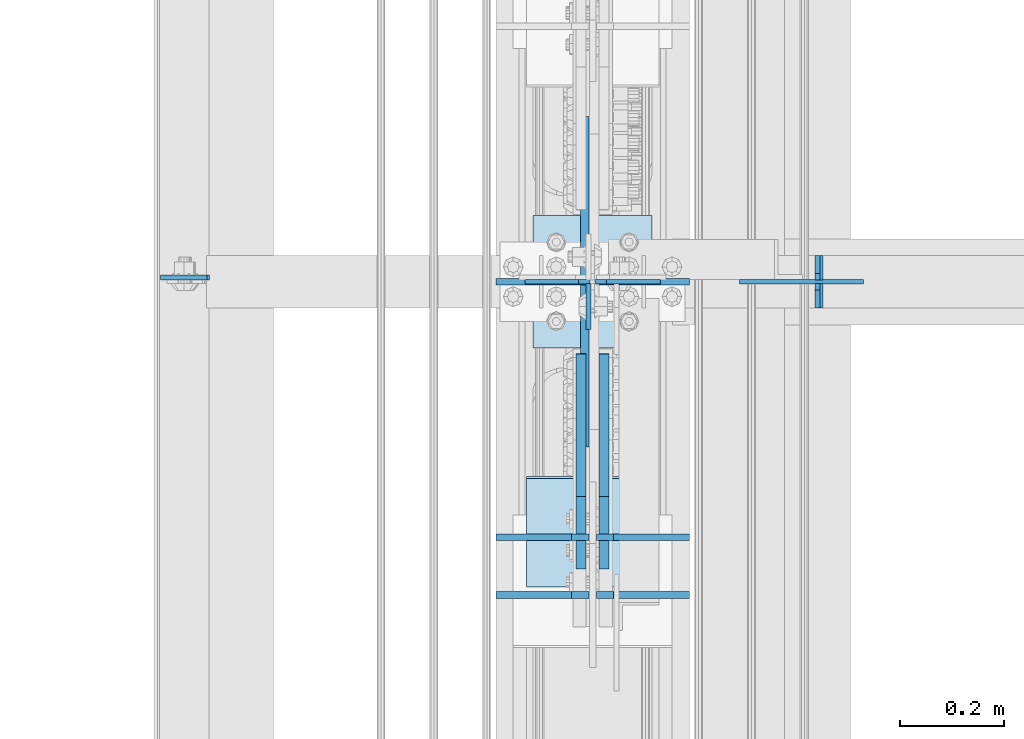
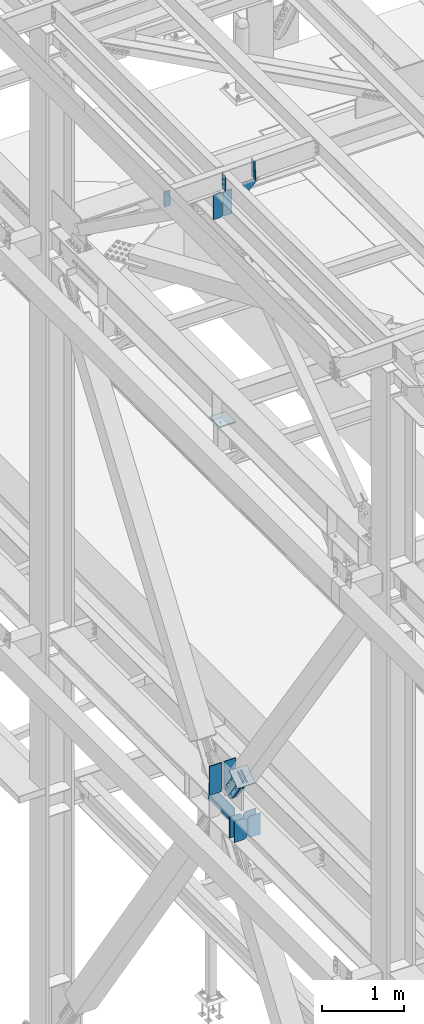
# One storey, part 3347 of 3843: 18 plates, 8 elements without a shape of their own.
"""IFC2X3 building model written with IfcOpenShell, lengths in millimetres."""

from ifc_helpers import new_model, si_unit, frame, origin_with_axes, place, context, subcontext, project, spatial, faceted_brep, material, type_object, element, aggregate, save


model = new_model("IFC2X3")

# Units and contexts
model_context = context("Model", 3, precision=1e-05, world=origin_with_axes())
body_context = subcontext(model_context, "Body", "Model", "MODEL_VIEW")
ifc_project = project(units=[si_unit("LENGTHUNIT", "METRE", prefix="MILLI"), si_unit("AREAUNIT", "SQUARE_METRE"), si_unit("VOLUMEUNIT", "CUBIC_METRE"), si_unit("MASSUNIT", "GRAM", prefix="KILO"), si_unit("TIMEUNIT", "SECOND"), si_unit("PLANEANGLEUNIT", "RADIAN"), si_unit("SOLIDANGLEUNIT", "STERADIAN"), si_unit("THERMODYNAMICTEMPERATUREUNIT", "DEGREE_CELSIUS"), si_unit("LUMINOUSINTENSITYUNIT", "LUMEN")], contexts=[model_context])

# Site, building, storey
site_placement = place(None, origin_with_axes())
site = spatial("IfcSite", under=ifc_project, at=site_placement, CompositionType="ELEMENT")
building_placement = place(site_placement, origin_with_axes())
building = spatial("IfcBuilding", under=site, at=building_placement, Name="Undefined", CompositionType="ELEMENT")
storey_placement = place(building_placement, origin_with_axes())
storey = spatial("IfcBuildingStorey", under=building, at=storey_placement, Name="Undefined", CompositionType="ELEMENT", Elevation=0.0)

# Assembly, plate
assembly_1_placement = place(storey_placement, origin_with_axes())
assembly_1 = element("IfcElementAssembly", 1, at=assembly_1_placement, inside=storey, Name="BEAM", AssemblyPlace="NOTDEFINED", PredefinedType="RIGID_FRAME")
ifc_material_1 = material(Name="STEEL/A572-50")
plate_type_1 = type_object("IfcPlateType", PredefinedType="NOTDEFINED")
plate_1_placement = place(assembly_1_placement, frame((36568.0624999624, 71447.0249999999, 45691.4946293707), z_axis=(0.0, -1.0, 0.0), x_axis=(0.0, 0.0, -1.0)))
plate_1 = element("IfcPlate", 2, at=plate_1_placement, type_object=plate_type_1, material=ifc_material_1, Name="PLATE", context=body_context, shape_type="Brep", body=[
    faceted_brep([(0.0, -4.76249999999709, 0.0), (0.0, -4.76249999999709, 88.9000015258789), (0.0, 4.76249999999709, 88.9000015258789), (0.0, 4.76249999999709, 0.0), (228.600006102781, -4.7625000004191, 88.9000015257589), (228.600006102781, 4.76249999954598, 88.9000015257443), (228.600006103079, -4.7625000004482, 7.27595761418343e-12), (228.600006103079, 4.76249999954598, -7.27595761418343e-12)], [[[0, 1, 2, 3]], [[1, 4, 5, 2]], [[4, 6, 7, 5]], [[6, 0, 3, 7]], [[5, 7, 3, 2]], [[6, 4, 1, 0]]]),
])

assembly_2_placement = place(storey_placement, origin_with_axes())
assembly_2 = element("IfcElementAssembly", 3, at=assembly_2_placement, inside=storey, Name="BEAM", AssemblyPlace="NOTDEFINED", PredefinedType="RIGID_FRAME")
plate_2_placement = place(assembly_2_placement, frame((35746.5416190487, 71458.1374999999, 45673.93739218), z_axis=(0.999776270257024, 0.0, 0.0211520550054619), x_axis=(0.0211520550054438, 0.0, -0.999776270257025)))
plate_2 = element("IfcPlate", 4, at=plate_2_placement, type_object=plate_type_1, material=ifc_material_1, Name="PLATE", context=body_context, shape_type="Brep", body=[
    faceted_brep([(0.0, -4.76249999999709, 0.0), (0.0, -4.76249999999709, 88.9000015258789), (0.0, 4.76249999999709, 88.9000015258789), (0.0, 4.76249999999709, 0.0), (228.600006102781, -4.7625000004191, 88.9000015257589), (228.600006102781, 4.76249999954598, 88.9000015257443), (228.600006103079, -4.7625000004482, 7.27595761418343e-12), (228.600006103079, 4.76249999954598, -7.27595761418343e-12)], [[[0, 1, 2, 3]], [[1, 4, 5, 2]], [[4, 6, 7, 5]], [[6, 0, 3, 7]], [[5, 7, 3, 2]], [[6, 4, 1, 0]]]),
])
aggregate(assembly_2, [plate_2])

# Plate
plate_type_2 = type_object("IfcPlateType", PredefinedType="NOTDEFINED")
plate_3_placement = place(assembly_1_placement, frame((37013.8586767906, 71399.3999999999, 45441.9293994939), z_axis=(-0.0211520980073474, 0.0, 0.999776269347241), x_axis=(0.0, 1.0, 0.0)))
plate_3 = element("IfcPlate", 5, at=plate_3_placement, type_object=plate_type_2, material=ifc_material_1, Name="STIFFENER", context=body_context, shape_type="Brep", body=[
    faceted_brep([(0.0, -4.76249999999709, 0.0), (0.0, -4.7624999997206, 285.749999997672), (0.0, 4.7625000002663, 285.749999997664), (0.0, 4.76249999999709, 0.0), (34.9250001907349, -4.7624999997206, 285.749999997672), (34.9250001907349, 4.7625000002663, 285.749999997664), (47.625, -4.76249999972788, 273.050000188428), (47.625, 4.76250000025902, 273.050000188421), (47.625, -4.76249999998981, 12.6999998092579), (47.625, 4.76249999999709, 12.6999998092506), (34.9250001907349, -4.76249999999709, 1.45519152283669e-11), (34.9250001907349, 4.76249999998254, 0.0)], [[[0, 1, 2, 3]], [[1, 4, 5, 2]], [[4, 6, 7, 5]], [[6, 8, 9, 7]], [[8, 10, 11, 9]], [[10, 0, 3, 11]], [[5, 7, 9, 11, 3, 2]], [[10, 8, 6, 4, 1, 0]]]),
])

plate_4_placement = place(assembly_1_placement, frame((37013.8586767906, 71453.3749999999, 45441.9293994939), z_axis=(-0.0211520980073474, 0.0, 0.999776269347241), x_axis=(0.0, 1.0, 0.0)))
plate_4 = element("IfcPlate", 6, at=plate_4_placement, type_object=plate_type_2, material=ifc_material_1, Name="STIFFENER", context=body_context, shape_type="Brep", body=[
    faceted_brep([(0.0, -4.76250000000073, 12.6999998092651), (0.0, -4.76250000000073, 273.050000188858), (0.0, 4.76250000000073, 273.050000188858), (0.0, 4.76250000000073, 12.6999998092651), (12.6999998092651, -4.76250000000073, 285.749999998123), (12.6999998092651, 4.76250000000073, 285.749999998123), (47.625, -4.76250000000073, 285.749999998123), (47.625, 4.76250000000073, 285.749999998123), (47.625, -4.76250000000073, 0.0), (47.625, 4.76250000000073, 0.0), (12.6999998092651, -4.76250000000073, 0.0), (12.6999998092651, 4.76250000000073, 0.0)], [[[0, 1, 2, 3]], [[1, 4, 5, 2]], [[4, 6, 7, 5]], [[6, 8, 9, 7]], [[8, 10, 11, 9]], [[10, 0, 3, 11]], [[5, 7, 9, 11, 3, 2]], [[10, 8, 6, 4, 1, 0]]]),
])

# Assembly, plates
assembly_3_placement = place(storey_placement, origin_with_axes())
assembly_3 = element("IfcElementAssembly", 7, at=assembly_3_placement, inside=storey, Name="BEAM", AssemblyPlace="NOTDEFINED", PredefinedType="RIGID_FRAME")
plate_type_3 = type_object("IfcPlateType", PredefinedType="NOTDEFINED")
plate_5_placement = place(assembly_3_placement, frame((36568.85625, 70848.9295924979, 36093.4), z_axis=(-1.0, 0.0, 0.0), x_axis=(0.0, 0.0, 1.0)))
plate_5 = element("IfcPlate", 8, at=plate_5_placement, type_object=plate_type_3, material=ifc_material_1, Name="CB_BEAM", context=body_context, shape_type="Brep", body=[
    faceted_brep([(0.0, -6.34999999999854, 33.3375015258789), (0.0, -6.34999999999854, 178.59375), (0.0, 6.34999999999854, 178.59375), (0.0, 6.34999999999854, 33.3375015258789), (317.499999999985, -6.34999999999854, 178.59375), (317.499999999985, 6.34999999999854, 178.59375), (317.499999999985, -6.34999999999854, 33.3375015258789), (317.499999999985, 6.34999999999854, 33.3375015258789), (284.162498474107, -6.34999999999854, 0.0), (284.162498474107, 6.34999999999854, 0.0), (33.3375015258789, -6.34999999999854, 0.0), (33.3375015258789, 6.34999999999854, 0.0)], [[[0, 1, 2, 3]], [[1, 4, 5, 2]], [[4, 6, 7, 5]], [[6, 8, 9, 7]], [[8, 10, 11, 9]], [[10, 0, 3, 11]], [[5, 7, 9, 11, 3, 2]], [[10, 8, 6, 4, 1, 0]]]),
])
plate_6_placement = place(assembly_3_placement, frame((36583.14375, 70848.9295924979, 36093.4), z_axis=(1.0, 0.0, 0.0), x_axis=(0.0, 0.0, 1.0)))
plate_6 = element("IfcPlate", 9, at=plate_6_placement, type_object=plate_type_3, material=ifc_material_1, Name="CB_BEAM", context=body_context, shape_type="Brep", body=[
    faceted_brep([(0.0, -6.34999999999854, 33.3375015258789), (0.0, -6.34999999999854, 178.59375), (0.0, 6.34999999999854, 178.59375), (0.0, 6.34999999999854, 33.3375015258789), (317.499999999985, -6.34999999999854, 178.59375), (317.499999999985, 6.34999999999854, 178.59375), (317.499999999985, -6.34999999999854, 33.3375015258789), (317.499999999985, 6.34999999999854, 33.3375015258789), (284.162498474107, -6.34999999999854, 0.0), (284.162498474107, 6.34999999999854, 0.0), (33.3375015258789, -6.34999999999854, 0.0), (33.3375015258789, 6.34999999999854, 0.0)], [[[0, 1, 2, 3]], [[1, 4, 5, 2]], [[4, 6, 7, 5]], [[6, 8, 9, 7]], [[8, 10, 11, 9]], [[10, 0, 3, 11]], [[5, 7, 9, 11, 3, 2]], [[10, 8, 6, 4, 1, 0]]]),
])
plate_7_placement = place(assembly_3_placement, frame((36568.85625, 70959.9507437756, 36093.4), z_axis=(-1.0, 0.0, 0.0), x_axis=(0.0, 0.0, 1.0)))
plate_7 = element("IfcPlate", 10, at=plate_7_placement, type_object=plate_type_3, material=ifc_material_1, Name="CB_BEAM", context=body_context, shape_type="Brep", body=[
    faceted_brep([(0.0, -6.34999999999854, 33.3375015258789), (0.0, -6.34999999999854, 178.59375), (0.0, 6.34999999999854, 178.59375), (0.0, 6.34999999999854, 33.3375015258789), (317.499999999985, -6.34999999999854, 178.59375), (317.499999999985, 6.34999999999854, 178.59375), (317.499999999985, -6.34999999999854, 33.3375015258789), (317.499999999985, 6.34999999999854, 33.3375015258789), (284.162498474107, -6.34999999999854, 0.0), (284.162498474107, 6.34999999999854, 0.0), (33.3375015258789, -6.34999999999854, 0.0), (33.3375015258789, 6.34999999999854, 0.0)], [[[0, 1, 2, 3]], [[1, 4, 5, 2]], [[4, 6, 7, 5]], [[6, 8, 9, 7]], [[8, 10, 11, 9]], [[10, 0, 3, 11]], [[5, 7, 9, 11, 3, 2]], [[10, 8, 6, 4, 1, 0]]]),
])
plate_8_placement = place(assembly_3_placement, frame((36583.14375, 70959.9507437756, 36093.4), z_axis=(1.0, 0.0, 0.0), x_axis=(0.0, 0.0, 1.0)))
plate_8 = element("IfcPlate", 11, at=plate_8_placement, type_object=plate_type_3, material=ifc_material_1, Name="CB_BEAM", context=body_context, shape_type="Brep", body=[
    faceted_brep([(0.0, -6.34999999999854, 33.3375015258789), (0.0, -6.34999999999854, 178.59375), (0.0, 6.34999999999854, 178.59375), (0.0, 6.34999999999854, 33.3375015258789), (317.499999999985, -6.34999999999854, 178.59375), (317.499999999985, 6.34999999999854, 178.59375), (317.499999999985, -6.34999999999854, 33.3375015258789), (317.499999999985, 6.34999999999854, 33.3375015258789), (284.162498474107, -6.34999999999854, 0.0), (284.162498474107, 6.34999999999854, 0.0), (33.3375015258789, -6.34999999999854, 0.0), (33.3375015258789, 6.34999999999854, 0.0)], [[[0, 1, 2, 3]], [[1, 4, 5, 2]], [[4, 6, 7, 5]], [[6, 8, 9, 7]], [[8, 10, 11, 9]], [[10, 0, 3, 11]], [[5, 7, 9, 11, 3, 2]], [[10, 8, 6, 4, 1, 0]]]),
])

assembly_4_placement = place(storey_placement, origin_with_axes())
assembly_4 = element("IfcElementAssembly", 12, at=assembly_4_placement, inside=storey, Name="BEAM", AssemblyPlace="NOTDEFINED", PredefinedType="RIGID_FRAME")
plate_type_4 = type_object("IfcPlateType", PredefinedType="NOTDEFINED")
plate_9_placement = place(assembly_4_placement, frame((36706.1750000579, 71450.1999991159, 45021.5000000007), z_axis=(0.0, 0.0, 1.0), x_axis=(-1.0, 0.0, 0.0)))
plate_9 = element("IfcPlate", 13, at=plate_9_placement, type_object=plate_type_4, material=ifc_material_1, Name="STIFFENER", context=body_context, shape_type="Brep", body=[
    faceted_brep([(0.0, -4.76249999999709, 0.0), (0.0, -4.76249999999709, 377.824999997538), (0.0, 4.76249999999709, 377.824999997538), (0.0, 4.76249999999709, 0.0), (103.187499618536, -4.76249999999709, 377.824999997538), (103.187499618536, 4.76249999999709, 377.824999997538), (125.412500000006, -4.76249999999709, 355.599999616068), (125.412500000006, 4.76249999999709, 355.599999616068), (125.412500000006, -4.76249999999709, 22.2250003814697), (125.412500000006, 4.76249999999709, 22.2250003814697), (103.187499618536, -4.76249999999709, 0.0), (103.187499618536, 4.76249999999709, 0.0)], [[[0, 1, 2, 3]], [[1, 4, 5, 2]], [[4, 6, 7, 5]], [[6, 8, 9, 7]], [[8, 10, 11, 9]], [[10, 0, 3, 11]], [[5, 7, 9, 11, 3, 2]], [[10, 8, 6, 4, 1, 0]]]),
])
plate_10_placement = place(assembly_4_placement, frame((36571.2375000579, 71450.1999991159, 45021.5000000007), z_axis=(0.0, 0.0, 1.0), x_axis=(-1.0, 0.0, 0.0)))
plate_10 = element("IfcPlate", 14, at=plate_10_placement, type_object=plate_type_4, material=ifc_material_1, Name="STIFFENER", context=body_context, shape_type="Brep", body=[
    faceted_brep([(0.0, -4.76249999999709, 22.2250003814697), (0.0, -4.76249999999709, 355.599999616068), (0.0, 4.76249999999709, 355.599999616068), (0.0, 4.76249999999709, 22.2250003814697), (22.2250003814697, -4.76249999999709, 377.824999997538), (22.2250003814697, 4.76249999999709, 377.824999997538), (125.412500000006, -4.76249999999709, 377.824999997538), (125.412500000006, 4.76249999999709, 377.824999997538), (125.412500000006, -4.76249999999709, 0.0), (125.412500000006, 4.76249999999709, 0.0), (22.2250003814697, -4.76249999999709, 0.0), (22.2250003814697, 4.76249999999709, 0.0)], [[[0, 1, 2, 3]], [[1, 4, 5, 2]], [[4, 6, 7, 5]], [[6, 8, 9, 7]], [[8, 10, 11, 9]], [[10, 0, 3, 11]], [[5, 7, 9, 11, 3, 2]], [[10, 8, 6, 4, 1, 0]]]),
])
aggregate(assembly_4, [plate_9, plate_10])

# Plate
plate_type_5 = type_object("IfcPlateType", PredefinedType="NOTDEFINED")
plate_11_placement = place(assembly_1_placement, frame((36857.7258091626, 71450.1999985331, 45427.5111359823), z_axis=(0.0211520550054438, 0.0, -0.999776270257025), x_axis=(0.999776270257024, 0.0, 0.0211520550054619)))
plate_11 = element("IfcPlate", 15, at=plate_11_placement, type_object=plate_type_5, material=ifc_material_1, Name="PLATE", context=body_context, shape_type="Brep", body=[
    faceted_brep([(0.0, -4.76249999999709, 0.0), (-0.000271083736151922, -4.7625000001135, 52.4356396771473), (-0.000271083757979795, 4.76249999988067, 52.4356396771473), (0.0, 4.76249999999709, 0.0), (87.8825045197955, -4.76250000033178, 144.117664585436), (87.8825045197736, 4.7624999996624, 144.11766458545), (238.230258310934, -4.76249999999709, -2.47382558882236e-10), (238.230258310919, 4.76249999999709, -2.25554686039686e-10)], [[[0, 1, 2, 3]], [[1, 4, 5, 2]], [[4, 6, 7, 5]], [[6, 0, 3, 7]], [[5, 7, 3, 2]], [[6, 4, 1, 0]]]),
])

aggregate(assembly_1, [plate_3, plate_4, plate_11, plate_1])

plate_type_6 = type_object("IfcPlateType", PredefinedType="NOTDEFINED")
plate_12_placement = place(assembly_3_placement, frame((36563.3, 71450.1999994305, 36436.3), z_axis=(-1.0, 0.0, 0.0), x_axis=(0.0, 0.0, 1.0)))
plate_12 = element("IfcPlate", 16, at=plate_12_placement, type_object=plate_type_6, material=ifc_material_1, Name="CB", context=body_context, shape_type="Brep", body=[
    faceted_brep([(0.0, -6.34999999999854, 19.0499992370605), (0.0, -6.34999999999854, 173.037500000006), (0.0, 6.34999999999854, 173.037500000006), (0.0, 6.34999999999854, 19.0499992370605), (435.0204289799, -6.35000000000582, 173.037500000006), (435.0204289799, 6.35000000000582, 173.037500000006), (435.0204289799, -6.35000000000582, 0.0), (435.0204289799, 6.35000000000582, 0.0), (19.0499992370605, -6.34999999999854, 0.0), (19.0499992370605, 6.34999999999854, 0.0)], [[[0, 1, 2, 3]], [[1, 4, 5, 2]], [[4, 6, 7, 5]], [[6, 8, 9, 7]], [[8, 0, 3, 9]], [[5, 7, 9, 3, 2]], [[8, 6, 4, 1, 0]]]),
])

plate_13_placement = place(assembly_3_placement, frame((36588.7, 71450.1999994305, 36436.3), z_axis=(1.0, 0.0, 0.0), x_axis=(0.0, 0.0, 1.0)))
plate_13 = element("IfcPlate", 17, at=plate_13_placement, type_object=plate_type_6, material=ifc_material_1, Name="CB", context=body_context, shape_type="Brep", body=[
    faceted_brep([(0.0, -6.34999999999854, 19.0499992370605), (0.0, -6.34999999999854, 173.037500000006), (0.0, 6.34999999999854, 173.037500000006), (0.0, 6.34999999999854, 19.0499992370605), (435.0204289799, -6.35000000000582, 173.037500000006), (435.0204289799, 6.35000000000582, 173.037500000006), (435.0204289799, -6.35000000000582, 0.0), (435.0204289799, 6.35000000000582, 0.0), (19.0499992370605, -6.34999999999854, 0.0), (19.0499992370605, 6.34999999999854, 0.0)], [[[0, 1, 2, 3]], [[1, 4, 5, 2]], [[4, 6, 7, 5]], [[6, 8, 9, 7]], [[8, 0, 3, 9]], [[5, 7, 9, 3, 2]], [[8, 6, 4, 1, 0]]]),
])

plate_type_7 = type_object("IfcPlateType", PredefinedType="NOTDEFINED")
plate_14_placement = place(assembly_3_placement, frame((36560.9187499996, 71132.699998691, 36379.1499984745), z_axis=(0.0, 0.0, -1.0), x_axis=(0.0, 1.0, 0.0)))
plate_14 = element("IfcPlate", 18, at=plate_14_placement, type_object=plate_type_7, material=ifc_material_1, Name="PLATE", context=body_context, shape_type="Brep", body=[
    faceted_brep([(0.0, 7.9375, 0.0), (635.0, 7.9375, 3.63797880709171e-10), (635.0, -7.9375, 9.16543575970718), (0.0, -7.9375, 9.16543575970718), (635.0, 7.9375, 253.999996948602), (635.0, -7.9375, 244.834561180331), (0.0, -7.9375, 244.834561180331), (0.0, 7.9375, 253.999996948245)], [[[0, 1, 2, 3]], [[2, 1, 4, 5]], [[3, 2, 5, 6]], [[0, 3, 6, 7]], [[1, 0, 7, 4]], [[6, 5, 4, 7]]]),
])

aggregate(assembly_3, [plate_5, plate_6, plate_7, plate_8, plate_14, plate_12, plate_13])

# Assembly, plate
assembly_5_placement = place(storey_placement, origin_with_axes())
assembly_5 = element("IfcElementAssembly", 19, at=assembly_5_placement, inside=storey, AssemblyPlace="NOTDEFINED", PredefinedType="RIGID_FRAME")
ifc_material_2 = material(Name="STEEL/A36")
plate_type_8 = type_object("IfcPlateType", PredefinedType="NOTDEFINED")
plate_15_placement = place(assembly_5_placement, frame((36553.775, 71037.5822231637, 36990.2561273857), z_axis=(0.0, -0.819732546373648, -0.572746499261039), x_axis=(0.0, 0.572746499261054, -0.819732546373637)))
plate_15 = element("IfcPlate", 20, at=plate_15_placement, type_object=plate_type_8, material=ifc_material_2, context=body_context, shape_type="Brep", body=[
    faceted_brep([(0.0, -9.52500000000146, 0.0), (-2.16823536902666e-09, -9.52499999999418, 169.022957228546), (-2.16823536902666e-09, 9.52499999999418, 169.022957228546), (0.0, 9.52500000000146, 0.0), (69.8499999974956, -9.52499999999418, 169.02295722875), (69.8499999974956, 9.52499999999418, 169.02295722875), (171.449999996829, -9.52499999999418, 181.348978614493), (171.449999996829, 9.52499999999418, 181.348978614493), (434.579297661258, -9.52499999999418, 181.348978615235), (434.579297661258, 9.52499999999418, 181.348978615235), (471.63740512668, -9.52499999999418, 173.977662728823), (471.63740512668, 9.52499999999418, 173.977662728823), (503.053751663178, -9.52499999999418, 152.985931091971), (503.053751663178, 9.52499999999418, 152.985931091971), (524.045483300536, -9.52499999999418, 121.569584555793), (524.045483300536, 9.52499999999418, 121.569584555793), (531.416799187516, -9.52499999999418, 84.511480142959), (531.416799187516, 9.52499999999418, 84.511480142959), (524.0454833013, -9.52499999999418, 47.4533726770169), (524.0454833013, 9.52499999999418, 47.4533726770169), (503.053751664252, -9.52499999999418, 16.0370261400676), (503.053751664252, 9.52499999999418, 16.0370261400676), (471.63740512763, -9.52499999999418, -4.95470549746824), (471.63740512763, 9.52499999999418, -4.95470549746824), (434.579299189239, -9.52499999999418, -12.3260213842586), (434.579299189239, 9.52499999999418, -12.3260213842586), (171.44999999931, -9.52499999999418, -12.3260213849862), (171.44999999931, 9.52499999999418, -12.3260213849862), (69.8499999979995, -9.52499999999418, -4.00177668780088e-10), (69.8499999979995, 9.52499999999418, -4.00177668780088e-10)], [[[0, 1, 2, 3]], [[1, 4, 5, 2]], [[4, 6, 7, 5]], [[6, 8, 9, 7]], [[8, 10, 11, 9]], [[10, 12, 13, 11]], [[12, 14, 15, 13]], [[14, 16, 17, 15]], [[16, 18, 19, 17]], [[18, 20, 21, 19]], [[20, 22, 23, 21]], [[22, 24, 25, 23]], [[24, 26, 27, 25]], [[26, 28, 29, 27]], [[28, 0, 3, 29]], [[5, 7, 9, 11, 13, 15, 17, 19, 21, 23, 25, 27, 29, 3, 2]], [[28, 26, 24, 22, 20, 18, 16, 14, 12, 10, 8, 6, 4, 1, 0]]]),
])
aggregate(assembly_5, [plate_15])

assembly_6_placement = place(storey_placement, origin_with_axes())
assembly_6 = element("IfcElementAssembly", 21, at=assembly_6_placement, inside=storey, AssemblyPlace="NOTDEFINED", PredefinedType="RIGID_FRAME")
plate_16_placement = place(assembly_6_placement, frame((36598.225, 71037.5822231637, 36990.2561273857), z_axis=(0.0, -0.819732546373648, -0.572746499261039), x_axis=(0.0, 0.572746499261054, -0.819732546373637)))
plate_16 = element("IfcPlate", 22, at=plate_16_placement, type_object=plate_type_8, material=ifc_material_2, context=body_context, shape_type="Brep", body=[
    faceted_brep([(0.0, -9.52500000000146, 0.0), (-2.16823536902666e-09, -9.52499999999418, 169.022957228546), (-2.16823536902666e-09, 9.52499999999418, 169.022957228546), (0.0, 9.52500000000146, 0.0), (69.8499999974956, -9.52499999999418, 169.02295722875), (69.8499999974956, 9.52499999999418, 169.02295722875), (171.449999996829, -9.52499999999418, 181.348978614493), (171.449999996829, 9.52499999999418, 181.348978614493), (434.579297661258, -9.52499999999418, 181.348978615235), (434.579297661258, 9.52499999999418, 181.348978615235), (471.63740512668, -9.52499999999418, 173.977662728823), (471.63740512668, 9.52499999999418, 173.977662728823), (503.053751663178, -9.52499999999418, 152.985931091971), (503.053751663178, 9.52499999999418, 152.985931091971), (524.045483300536, -9.52499999999418, 121.569584555793), (524.045483300536, 9.52499999999418, 121.569584555793), (531.416799187516, -9.52499999999418, 84.511480142959), (531.416799187516, 9.52499999999418, 84.511480142959), (524.0454833013, -9.52499999999418, 47.4533726770169), (524.0454833013, 9.52499999999418, 47.4533726770169), (503.053751664252, -9.52499999999418, 16.0370261400676), (503.053751664252, 9.52499999999418, 16.0370261400676), (471.63740512763, -9.52499999999418, -4.95470549746824), (471.63740512763, 9.52499999999418, -4.95470549746824), (434.579299189239, -9.52499999999418, -12.3260213842586), (434.579299189239, 9.52499999999418, -12.3260213842586), (171.44999999931, -9.52499999999418, -12.3260213849862), (171.44999999931, 9.52499999999418, -12.3260213849862), (69.8499999979995, -9.52499999999418, -4.00177668780088e-10), (69.8499999979995, 9.52499999999418, -4.00177668780088e-10)], [[[0, 1, 2, 3]], [[1, 4, 5, 2]], [[4, 6, 7, 5]], [[6, 8, 9, 7]], [[8, 10, 11, 9]], [[10, 12, 13, 11]], [[12, 14, 15, 13]], [[14, 16, 17, 15]], [[16, 18, 19, 17]], [[18, 20, 21, 19]], [[20, 22, 23, 21]], [[22, 24, 25, 23]], [[24, 26, 27, 25]], [[26, 28, 29, 27]], [[28, 0, 3, 29]], [[5, 7, 9, 11, 13, 15, 17, 19, 21, 23, 25, 27, 29, 3, 2]], [[28, 26, 24, 22, 20, 18, 16, 14, 12, 10, 8, 6, 4, 1, 0]]]),
])
aggregate(assembly_6, [plate_16])

assembly_7_placement = place(storey_placement, origin_with_axes())
assembly_7 = element("IfcElementAssembly", 23, at=assembly_7_placement, inside=storey, Name="Plate", AssemblyPlace="NOTDEFINED", PredefinedType="RIGID_FRAME")
plate_type_9 = type_object("IfcPlateType", PredefinedType="NOTDEFINED")
plate_17_placement = place(assembly_7_placement, frame((36449.0, 70866.0178503398, 36866.5110176275), z_axis=(0.0, 0.819732546373636, 0.572746499261056), x_axis=(1.0, 0.0, 0.0)))
plate_17 = element("IfcPlate", 24, at=plate_17_placement, type_object=plate_type_9, material=ifc_material_2, Name="Plate", context=body_context, shape_type="Brep", body=[
    faceted_brep([(0.0, -3.17499999999927, 0.0), (0.0, -3.17499999965185, 254.000000005151), (0.0, 3.17500000035216, 254.000000005166), (0.0, 3.17499999999927, 0.0), (254.0, -3.17499999965185, 254.000000005151), (254.0, 3.17500000035216, 254.000000005166), (254.0, -3.17500000000291, 0.0), (254.0, 3.17499999999927, 1.45519152283669e-11)], [[[0, 1, 2, 3]], [[1, 4, 5, 2]], [[4, 6, 7, 5]], [[6, 0, 3, 7]], [[5, 7, 3, 2]], [[6, 4, 1, 0]]]),
])
aggregate(assembly_7, [plate_17])

assembly_8_placement = place(storey_placement, origin_with_axes())
assembly_8 = element("IfcElementAssembly", 25, at=assembly_8_placement, inside=storey, Name="POST", AssemblyPlace="NOTDEFINED", PredefinedType="RIGID_FRAME")
plate_type_10 = type_object("IfcPlateType", PredefinedType="NOTDEFINED")
plate_18_placement = place(assembly_8_placement, frame((36461.700000099, 71577.2, 41986.2), z_axis=(0.0, -1.0, 0.0), x_axis=(1.0, 0.0, 0.0)))
plate_18 = element("IfcPlate", 26, at=plate_18_placement, type_object=plate_type_10, material=ifc_material_1, Name="PLATE", context=body_context, shape_type="Brep", body=[
    faceted_brep([(0.0, -9.52500000000146, 0.0), (0.0, -9.52500000000146, 254.0), (0.0, 9.52500000000146, 254.0), (0.0, 9.52500000000146, 0.0), (228.599999999999, -9.52500000000146, 254.0), (228.599999999999, 9.52500000000146, 254.0), (228.599999999999, -9.52500000000146, 0.0), (228.599999999999, 9.52500000000146, 0.0)], [[[0, 1, 2, 3]], [[1, 4, 5, 2]], [[4, 6, 7, 5]], [[6, 0, 3, 7]], [[5, 7, 3, 2]], [[6, 4, 1, 0]]]),
])
aggregate(assembly_8, [plate_18])

save(model, "model.ifc")
